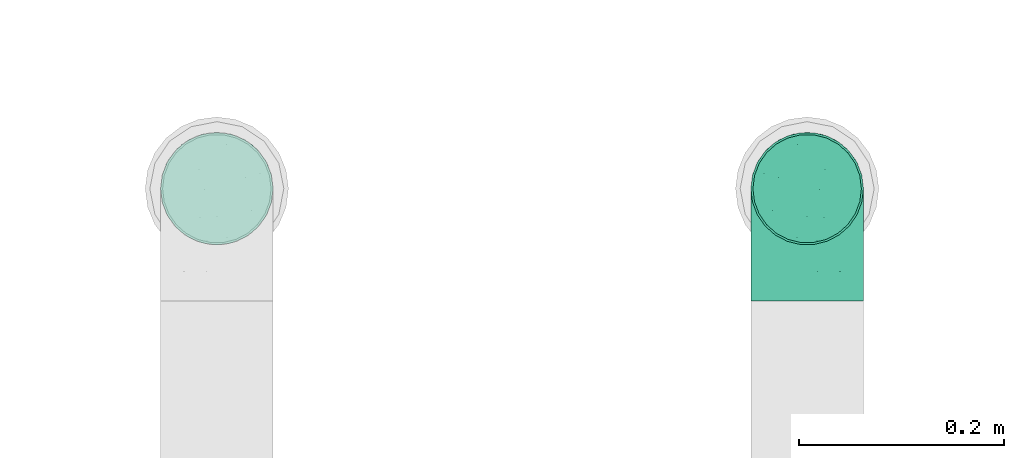
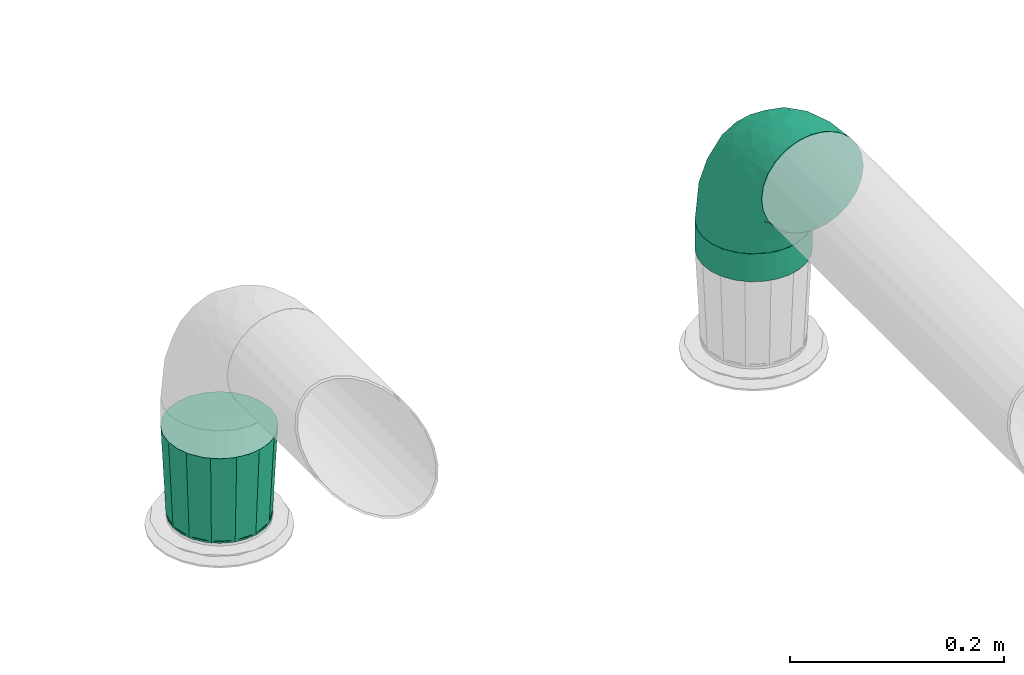
# One storey, part 65 of 103: 2 flow fittings, 1 flow segment.
"""IFC2X3 building model written with IfcOpenShell, lengths in millimetres."""

from ifc_helpers import new_model, entity, si_unit, converted_unit, derived_unit, direction, frame, origin_with_axes, origin_2d_with_axis, place, context, subcontext, project, spatial, hollow_circle, extrude, open_shell, surface_model, source, transform, mapped, material, layer, layer_set, layer_usage, type_object, element, save


model = new_model("IFC2X3")

# Units and contexts
model_context = context("Model", 3, precision=1e-05, world=origin_with_axes(), true_north=direction((0.0, 1.0)))
body_context = subcontext(model_context, "Body", "Model", "MODEL_VIEW")
ifc_project = project(units=[si_unit("AREAUNIT", "SQUARE_METRE"), si_unit("VOLUMEUNIT", "CUBIC_METRE", prefix="DECI"), si_unit("TIMEUNIT", "SECOND"), si_unit("THERMODYNAMICTEMPERATUREUNIT", "DEGREE_CELSIUS"), si_unit("PRESSUREUNIT", "PASCAL"), si_unit("MASSUNIT", "GRAM", prefix="KILO"), si_unit("LENGTHUNIT", "METRE", prefix="MILLI"), si_unit("POWERUNIT", "WATT"), si_unit("ELECTRICCURRENTUNIT", "AMPERE"), si_unit("ELECTRICVOLTAGEUNIT", "VOLT"), derived_unit("VOLUMETRICFLOWRATEUNIT", [(si_unit("VOLUMEUNIT", "CUBIC_METRE", prefix="DECI"), 1), (si_unit("TIMEUNIT", "SECOND"), -1)]), derived_unit("LINEARVELOCITYUNIT", [(si_unit("LENGTHUNIT", "METRE"), 1), (si_unit("TIMEUNIT", "SECOND"), -1)]), derived_unit("MASSDENSITYUNIT", [(si_unit("MASSUNIT", "GRAM", prefix="KILO"), 1), (si_unit("VOLUMEUNIT", "CUBIC_METRE"), -1)]), converted_unit("PLANEANGLEUNIT", "DEGREE", entity("IfcRatioMeasure", 0.01745), si_unit("PLANEANGLEUNIT", "RADIAN"), dimensions=[0, 0, 0, 0, 0, 0, 0])], contexts=[model_context])

# Site, building, storey
site_placement = place(None, origin_with_axes())
site = spatial("IfcSite", under=ifc_project, at=site_placement, CompositionType="ELEMENT")
building_placement = place(site_placement, origin_with_axes())
building = spatial("IfcBuilding", under=site, at=building_placement, Name="mc-building", CompositionType="ELEMENT")
storey_placement = place(building_placement, frame((0.0, 0.0, 5900.0), z_axis=(0.0, 0.0, 1.0), x_axis=(1.0, 0.0, 0.0)))
storey = spatial("IfcBuildingStorey", under=building, at=storey_placement, Name="3. Korrus", CompositionType="ELEMENT", Elevation=5900.0)

# Flow segment
ifc_material = material(Name="FZ1")
ifc_layer = layer(ifc_material, 0.0)
ifc_layer_set = layer_set([ifc_layer], Name="FZ1")
ifc_layer_usage = layer_usage(ifc_layer_set, "AXIS1", "POSITIVE", 0.0)
duct_segment_type = type_object("IfcDuctSegmentType", PredefinedType="RIGIDSEGMENT")
shared_shape_1 = source(origin_with_axes(), body_context, "Body", "SweptSolid", [
    extrude(hollow_circle(Radius=55.0, WallThickness=2.0, at=origin_2d_with_axis()), frame((0.0, 0.0, 0.0), z_axis=(1.0, 0.0, 0.0), x_axis=(0.0, 1.0, 0.0)), (0.0, 0.0, 1.0), 31.9),
])
flow_segment_placement = place(storey_placement, frame((26665.96154, 4730.85862, 2235.0), z_axis=(0.0, -1.0, 0.0), x_axis=(0.0, 0.0, -1.0)))
element("IfcFlowSegment", 1, at=flow_segment_placement, inside=storey, type_object=duct_segment_type, material=ifc_layer_usage, context=body_context, shape_type="MappedRepresentation", body=[
    mapped(shared_shape_1, transform((0.0, 0.0, 0.0), scale=1.0)),
])

# Flow fittings
duct_fitting_type_1 = type_object("IfcDuctFittingType", Name="BU", PredefinedType="BEND")
shared_shape_2 = source(origin_with_axes(), body_context, "Body", "SurfaceModel", [
    surface_model("IfcShellBasedSurfaceModel", [(-110.0, 0.0, -55.0), (-110.0, -14.23505, -53.12592), (-110.0, 14.23505, -53.12592), (-110.0, 53.12592, 14.23505), (-110.0, 27.5, -47.63139), (-110.0, 38.89087, -38.89087), (-110.0, -55.0, 0.0), (-110.0, -53.12592, 14.23505), (-110.0, -38.89087, -38.89087), (-110.0, -27.5, -47.63139), (-110.0, -53.12592, -14.23505), (-110.0, -47.63139, -27.5), (-110.0, -14.23505, 53.12592), (-110.0, 14.23505, 53.12592), (-110.0, 27.5, 47.63139), (-110.0, -47.63139, 27.5), (-110.0, -38.89087, 38.89087), (-110.0, -27.5, 47.63139), (-110.0, 0.0, 55.0), (-110.0, 55.0, 0.0), (-110.0, 53.12592, -14.23505), (-110.0, 47.63139, -27.5), (-110.0, 47.63139, 27.5), (-110.0, 38.89087, 38.89087), (-14.23505, 110.0, -53.12592), (-55.0, 110.0, 0.0), (0.0, 110.0, -55.0), (-27.5, 110.0, -47.63139), (-38.89087, 110.0, -38.89087), (-47.63139, 110.0, -27.5), (38.89087, 110.0, -38.89087), (53.12592, 110.0, 14.23505), (27.5, 110.0, -47.63139), (14.23505, 110.0, -53.12592), (47.63139, 110.0, -27.5), (53.12592, 110.0, -14.23505), (55.0, 110.0, 0.0), (-53.12592, 110.0, -14.23505), (-53.12592, 110.0, 14.23505), (-47.63139, 110.0, 27.5), (-38.89087, 110.0, 38.89087), (-27.5, 110.0, 47.63139), (0.0, 110.0, 55.0), (-14.23505, 110.0, 53.12592), (38.89087, 110.0, 38.89087), (47.63139, 110.0, 27.5), (27.5, 110.0, 47.63139), (14.23505, 110.0, 53.12592), (-64.21732, 48.68956, 43.63444), (-76.6405, 38.18013, 45.55988), (-60.44912, 32.56953, 51.94617), (-76.00813, 5.38378, 55.0), (-90.15553, 11.94394, 54.09138), (-78.5998, 26.77405, 50.81338), (-70.18771, 18.55163, 54.03432), (-75.55424, 54.2118, 32.41257), (-93.27622, 45.77614, 33.48188), (-96.12334, 22.13664, 50.81337), (-21.00813, 45.34362, 55.0), (-18.36258, 70.48427, 54.04484), (-32.04182, 59.64019, 52.24446), (-63.88653, 74.77858, 17.99134), (-74.66383, 63.08407, 19.92123), (-63.60674, 66.07878, 29.97482), (-99.597, 52.72185, 18.52927), (-93.11138, 56.59448, 10.50359), (-98.21577, 57.34403, 0.0), (-53.42855, 92.60092, 21.04759), (-88.54852, 54.8376, 21.04759), (-11.86161, 90.23965, 54.10313), (-5.38378, 76.00813, 55.0), (-57.34403, 98.21577, 0.0), (-56.64619, 93.12774, 10.22088), (-45.34362, 21.00813, 55.0), (-44.60838, 44.60838, 52.13415), (-92.68484, 35.46673, 43.63443), (-22.25266, 95.40765, 50.81337), (-35.97783, 90.61597, 43.63443), (-43.70931, 69.58671, 44.47149), (-27.23711, 77.39884, 50.81337), (-57.2828, 79.3123, 24.9774), (-58.67786, 84.31125, 16.04456), (-82.93277, 60.36161, 12.91784), (-49.88337, 54.51816, 47.224), (-74.57753, 66.83759, 9.55742), (-45.35812, 94.97281, 33.48188), (-59.18663, 88.95241, 0.0), (-51.517, 78.6292, 33.48188), (-65.14788, 80.03077, 0.0), (-56.45322, 62.06476, 39.63545), (-88.95241, 59.18663, 0.0), (-71.10913, 71.10913, 0.0), (-80.03077, 65.14788, 0.0), (-94.9309, 45.36788, -33.48188), (-93.11358, 56.60141, -10.46614), (-99.64997, 52.79499, -18.30015), (-90.20425, 36.08686, -43.63443), (-79.99933, 46.56772, -37.92748), (-76.00813, 5.38378, -55.0), (-72.75364, 19.68651, -53.60527), (-45.34362, 21.00813, -55.0), (-21.91957, 65.12078, -53.85897), (-5.38378, 76.00813, -55.0), (-21.00813, 45.34362, -55.0), (-35.41876, 92.89265, -43.63443), (-91.10309, 11.02766, -54.21832), (-45.77614, 93.27622, -33.48188), (-90.50474, 23.21022, -50.81337), (-70.92854, 33.31794, -49.51754), (-78.52933, 63.35627, -11.73997), (-24.91508, 84.05606, -50.81337), (-88.78941, 54.74452, -21.04759), (-69.59921, 57.34866, -33.48187), (-73.36422, 62.46673, -22.94182), (-63.49062, 67.59111, -28.46929), (-56.59448, 93.11138, -10.50359), (-54.8376, 88.54852, -21.04759), (-54.10679, 75.85581, -32.31867), (-57.75956, 31.09612, -52.80882), (-52.72185, 99.597, -18.52927), (-12.62913, 89.46304, -53.99097), (-34.46825, 66.46123, -50.04329), (-43.9837, 43.9837, -52.42279), (-65.78527, 72.58348, -17.68796), (-70.34468, 43.65295, -44.21951), (-57.47001, 51.99467, -44.91465), (-60.72547, 82.29174, -12.88567), (-42.34915, 74.24548, -43.63444), (-57.25194, 63.5016, -38.08211), (-80.95344, 53.56991, -29.32027), (-52.32891, 4.55257, -54.0482), (32.52942, 47.13398, -30.48571), (14.88266, 20.92917, -33.7947), (14.95561, 36.05775, -42.26543), (30.24048, 70.09027, -41.7461), (19.3559, 65.35825, -48.00507), (-70.35075, -46.44478, -19.5952), (-47.13398, -32.52942, -30.48571), (-28.49299, -30.5778, -16.4009), (-4.55257, 52.32891, -54.0482), (-22.4954, 22.4954, -53.25347), (-75.47368, -11.22546, -52.60718), (-81.32209, -51.5606, -9.98467), (-80.81763, -41.84862, -32.14655), (-70.09027, -30.24048, -41.7461), (-36.05774, -14.95561, -42.26543), (-9.15831, -10.852, -27.8997), (-65.35825, -19.3559, -48.00507), (11.22546, 75.47368, -52.60718), (3.94376, 43.9333, -50.53315), (-13.39742, 13.39743, -48.13058), (-43.9333, -3.94376, -50.53315), (49.37776, 67.29486, 0.0), (41.8609, 47.82256, -9.92641), (50.20582, 74.51695, -9.9731), (18.93131, 11.7156, -17.56239), (-27.5, -32.89419, 0.0), (-1.23348, -12.25375, -12.18106), (41.84862, 80.81763, -32.14655), (35.70604, 41.31408, -20.38235), (46.44478, 70.35075, -19.5952), (32.89419, 27.5, 0.0), (6.67262, -6.67262, 0.0), (-67.29486, -49.37776, 0.0), (-50.36265, -42.95545, -9.51562), (-5.47251, 5.47251, -39.92906), (-70.35075, -46.44478, 19.5952), (-74.51695, -50.20582, 9.9731), (-41.31407, -35.70604, 20.38235), (-47.13398, -32.52942, 30.48571), (-80.81763, -41.84862, 32.14655), (-4.55257, 52.32891, 54.0482), (11.22546, 75.47368, 52.60718), (-43.9333, -3.94376, 50.53315), (-65.35825, -19.3559, 48.00507), (-36.05774, -14.95561, 42.26543), (-70.09027, -30.24048, 41.7461), (-11.7156, -18.93131, 17.56239), (30.5778, 28.49299, 16.4009), (12.25375, 1.23348, 12.18106), (51.5606, 81.32209, 9.98467), (42.95545, 50.36265, 9.51562), (-75.47368, -11.22546, 52.60718), (-52.32891, 4.55257, 54.0482), (3.94376, 43.9333, 50.53315), (-22.4954, 22.4954, 53.25347), (-13.39742, 13.39743, 48.13058), (10.852, 9.15831, 27.8997), (-20.92916, -14.88266, 33.79469), (-47.82256, -41.8609, 9.92641), (32.52942, 47.13398, 30.48571), (46.44478, 70.35075, 19.5952), (41.84862, 80.81763, 32.14655), (30.24048, 70.09027, 41.7461), (19.3559, 65.35825, 48.00507), (14.95561, 36.05775, 42.26543), (-5.47251, 5.47251, 39.92906)], [open_shell([[[0, 1, 2]], [[2, 3, 4]], [[4, 3, 5]], [[2, 6, 7]], [[8, 6, 9]], [[1, 9, 6]], [[10, 6, 11]], [[8, 11, 6]], [[6, 2, 1]], [[12, 13, 14]], [[15, 2, 7]], [[16, 17, 2]], [[2, 17, 12]], [[12, 18, 13]], [[19, 20, 3]], [[5, 3, 21]], [[20, 21, 3]], [[22, 3, 2]], [[23, 22, 2]], [[12, 14, 2]], [[2, 14, 23]], [[15, 16, 2]], [[24, 25, 26]], [[27, 25, 24]], [[25, 28, 29]], [[28, 25, 27]], [[30, 26, 31]], [[26, 30, 32]], [[32, 33, 26]], [[34, 31, 35]], [[31, 34, 30]], [[35, 31, 36]], [[29, 37, 25]], [[38, 39, 26]], [[39, 40, 26]], [[41, 42, 40]], [[42, 26, 40]], [[42, 41, 43]], [[26, 44, 45]], [[31, 26, 45]], [[26, 46, 44]], [[47, 46, 26]], [[42, 47, 26]], [[25, 38, 26]], [[48, 49, 50]], [[18, 51, 52]], [[53, 54, 50]], [[55, 56, 49]], [[56, 22, 23]], [[13, 57, 14]], [[58, 59, 60]], [[61, 62, 63]], [[3, 64, 65]], [[53, 52, 54]], [[3, 65, 66]], [[67, 39, 38]], [[56, 68, 64]], [[65, 64, 68]], [[69, 59, 70]], [[38, 71, 72]], [[73, 58, 74]], [[75, 49, 56]], [[76, 69, 43]], [[53, 57, 52]], [[77, 78, 79]], [[41, 76, 43]], [[43, 69, 42]], [[55, 68, 56]], [[23, 14, 75]], [[76, 77, 79]], [[80, 67, 81]], [[62, 82, 68]], [[60, 78, 83]], [[62, 84, 82]], [[85, 77, 40]], [[81, 67, 72]], [[86, 72, 71]], [[87, 85, 67]], [[61, 81, 88]], [[77, 41, 40]], [[78, 77, 87]], [[23, 75, 56]], [[83, 89, 48]], [[85, 40, 39]], [[62, 68, 55]], [[89, 87, 63]], [[83, 48, 50]], [[57, 75, 14]], [[49, 75, 53]], [[67, 85, 39]], [[87, 77, 85]], [[63, 62, 55]], [[89, 55, 48]], [[80, 63, 87]], [[66, 65, 90]], [[66, 19, 3]], [[84, 91, 92]], [[92, 90, 82]], [[65, 82, 90]], [[61, 84, 62]], [[92, 82, 84]], [[68, 82, 65]], [[3, 22, 64]], [[56, 64, 22]], [[38, 25, 71]], [[81, 72, 86]], [[38, 72, 67]], [[91, 61, 88]], [[80, 81, 61]], [[63, 80, 61]], [[67, 80, 87]], [[77, 76, 41]], [[79, 59, 69]], [[79, 69, 76]], [[42, 69, 70]], [[60, 59, 79]], [[58, 70, 59]], [[78, 60, 79]], [[58, 60, 74]], [[52, 57, 13]], [[75, 57, 53]], [[18, 52, 13]], [[52, 51, 54]], [[51, 73, 54]], [[50, 73, 74]], [[73, 50, 54]], [[50, 74, 83]], [[60, 83, 74]], [[89, 83, 78]], [[87, 89, 78]], [[55, 89, 63]], [[50, 49, 53]], [[55, 49, 48]], [[81, 86, 88]], [[91, 84, 61]], [[5, 21, 93]], [[90, 94, 66]], [[20, 94, 95]], [[96, 93, 97]], [[98, 99, 100]], [[96, 4, 5]], [[101, 102, 103]], [[28, 27, 104]], [[2, 105, 0]], [[104, 106, 28]], [[99, 105, 107]], [[108, 107, 96]], [[90, 109, 94]], [[107, 2, 4]], [[20, 66, 94]], [[27, 24, 110]], [[109, 111, 94]], [[112, 113, 114]], [[37, 115, 71]], [[116, 106, 117]], [[99, 118, 100]], [[116, 115, 119]], [[37, 119, 115]], [[24, 120, 110]], [[121, 110, 101]], [[119, 106, 116]], [[101, 110, 120]], [[122, 103, 100]], [[117, 123, 116]], [[124, 125, 108]], [[115, 116, 126]], [[106, 29, 28]], [[26, 102, 120]], [[127, 104, 110]], [[97, 124, 96]], [[125, 122, 118]], [[128, 127, 125]], [[96, 5, 93]], [[115, 126, 86]], [[117, 106, 127]], [[111, 113, 129]], [[95, 93, 21]], [[97, 129, 112]], [[110, 104, 27]], [[106, 104, 127]], [[96, 107, 4]], [[99, 107, 108]], [[99, 108, 118]], [[105, 99, 98]], [[112, 114, 128]], [[121, 125, 127]], [[20, 19, 66]], [[109, 90, 92]], [[94, 111, 95]], [[91, 123, 109]], [[129, 113, 112]], [[93, 95, 111]], [[21, 20, 95]], [[71, 115, 86]], [[71, 25, 37]], [[123, 91, 88]], [[126, 116, 123]], [[123, 88, 126]], [[86, 126, 88]], [[37, 29, 119]], [[106, 119, 29]], [[129, 93, 111]], [[124, 112, 125]], [[0, 105, 98]], [[107, 105, 2]], [[125, 118, 108]], [[100, 118, 122]], [[93, 129, 97]], [[113, 111, 109]], [[109, 123, 113]], [[114, 123, 117]], [[123, 114, 113]], [[128, 114, 117]], [[127, 128, 117]], [[112, 128, 125]], [[103, 122, 101]], [[110, 121, 127]], [[101, 122, 121]], [[125, 121, 122]], [[26, 120, 24]], [[101, 120, 102]], [[96, 124, 108]], [[92, 91, 109]], [[112, 124, 97]], [[100, 130, 98]], [[131, 132, 133]], [[32, 134, 135]], [[136, 137, 138]], [[139, 140, 103]], [[98, 141, 0]], [[142, 10, 136]], [[143, 144, 137]], [[6, 10, 142]], [[137, 145, 146]], [[144, 147, 145]], [[143, 136, 11]], [[11, 136, 10]], [[8, 143, 11]], [[148, 149, 139]], [[8, 9, 144]], [[9, 1, 147]], [[130, 141, 98]], [[103, 140, 100]], [[148, 135, 149]], [[150, 151, 140]], [[152, 153, 154]], [[130, 140, 151]], [[148, 26, 33]], [[147, 1, 141]], [[155, 146, 132]], [[156, 138, 157]], [[134, 30, 158]], [[150, 140, 149]], [[158, 30, 34]], [[30, 134, 32]], [[153, 159, 160]], [[131, 160, 159]], [[144, 145, 137]], [[36, 152, 154]], [[146, 138, 137]], [[155, 161, 162]], [[158, 160, 131]], [[133, 149, 135]], [[156, 163, 164]], [[163, 142, 164]], [[139, 103, 102]], [[153, 152, 161]], [[34, 35, 160]], [[162, 157, 155]], [[132, 165, 133]], [[157, 146, 155]], [[140, 130, 100]], [[141, 130, 151]], [[141, 151, 147]], [[141, 1, 0]], [[102, 26, 148]], [[140, 139, 149]], [[102, 148, 139]], [[135, 33, 32]], [[151, 150, 145]], [[9, 147, 144]], [[151, 145, 147]], [[145, 165, 146]], [[135, 148, 33]], [[133, 135, 134]], [[131, 133, 134]], [[133, 165, 150]], [[133, 150, 149]], [[145, 150, 165]], [[132, 131, 159]], [[146, 165, 132]], [[160, 158, 34]], [[134, 158, 131]], [[144, 143, 8]], [[136, 143, 137]], [[155, 153, 161]], [[154, 153, 160]], [[153, 155, 159]], [[132, 159, 155]], [[160, 35, 154]], [[36, 154, 35]], [[164, 136, 138]], [[6, 142, 163]], [[136, 164, 142]], [[156, 164, 138]], [[156, 157, 162]], [[146, 157, 138]], [[15, 7, 166]], [[6, 163, 167]], [[168, 169, 166]], [[166, 169, 170]], [[171, 172, 70]], [[173, 174, 175]], [[17, 176, 174]], [[177, 156, 162]], [[176, 16, 170]], [[170, 16, 15]], [[161, 178, 179]], [[152, 180, 181]], [[182, 173, 183]], [[18, 12, 182]], [[184, 185, 186]], [[183, 185, 73]], [[183, 73, 51]], [[177, 187, 188]], [[189, 168, 166]], [[187, 178, 190]], [[16, 176, 17]], [[161, 152, 181]], [[45, 191, 31]], [[45, 44, 192]], [[192, 191, 45]], [[180, 36, 31]], [[193, 194, 195]], [[46, 47, 194]], [[193, 195, 190]], [[193, 44, 46]], [[172, 42, 70]], [[185, 58, 73]], [[189, 163, 156]], [[163, 189, 167]], [[70, 58, 171]], [[184, 171, 185]], [[169, 188, 175]], [[180, 31, 191]], [[192, 193, 190]], [[191, 190, 178]], [[182, 174, 173]], [[194, 47, 172]], [[190, 195, 187]], [[186, 185, 173]], [[162, 179, 177]], [[188, 196, 175]], [[179, 187, 177]], [[185, 171, 58]], [[172, 171, 184]], [[172, 184, 194]], [[172, 47, 42]], [[51, 18, 182]], [[185, 183, 173]], [[51, 182, 183]], [[174, 12, 17]], [[184, 186, 195]], [[46, 194, 193]], [[184, 195, 194]], [[195, 196, 187]], [[174, 182, 12]], [[175, 174, 176]], [[169, 175, 176]], [[175, 196, 186]], [[175, 186, 173]], [[195, 186, 196]], [[188, 169, 168]], [[187, 196, 188]], [[166, 170, 15]], [[176, 170, 169]], [[193, 192, 44]], [[191, 192, 190]], [[177, 189, 156]], [[167, 189, 166]], [[189, 177, 168]], [[188, 168, 177]], [[166, 7, 167]], [[6, 167, 7]], [[181, 191, 178]], [[36, 180, 152]], [[191, 181, 180]], [[161, 181, 178]], [[161, 179, 162]], [[187, 179, 178]]])]),
])
flow_fitting_1_placement = place(storey_placement, frame((26665.96154, 4730.85862, 2345.0), z_axis=(-1.0, 0.0, 0.0), x_axis=(0.0, 1.0, 0.0)))
element("IfcFlowFitting", 2, at=flow_fitting_1_placement, inside=storey, type_object=duct_fitting_type_1, Name="BU", context=body_context, shape_type="MappedRepresentation", body=[
    mapped(shared_shape_2, transform((0.0, 0.0, 0.0), scale=1.0)),
])
duct_fitting_type_2 = type_object("IfcDuctFittingType", PredefinedType="TRANSITION")
shared_shape_3 = source(origin_with_axes(), body_context, "Body", "SurfaceModel", [
    surface_model("IfcShellBasedSurfaceModel", [(100.0, -55.0, 0.0), (100.0, -12.23865, 53.62104), (100.0, -34.29194, 43.00073), (100.0, 49.55329, 23.86361), (100.0, 34.29194, 43.00073), (100.0, 49.55329, -23.86361), (0.0, -45.04844, -21.69419), (0.0, -50.0, 0.0), (0.0, -45.04844, 21.69419), (0.0, 31.17449, 39.09157), (0.0, 45.04844, 21.69419), (0.0, 50.0, 0.0), (98.0, 47.63139, 27.5), (98.0, 0.0, 55.0), (98.0, 38.89087, 38.89087), (98.0, -38.89087, 38.89087), (98.0, -47.63139, 27.5), (100.0, 12.23865, 53.62104), (100.0, -49.55329, 23.86361), (100.0, 55.0, 0.0), (100.0, 12.23865, -53.62104), (100.0, 34.29194, -43.00073), (100.0, -49.55329, -23.86361), (100.0, -34.29194, -43.00073), (100.0, -12.23865, -53.62104), (0.0, -31.17449, 39.09157), (0.0, -11.12605, 48.7464), (0.0, 11.12605, 48.7464), (0.0, -31.17449, -39.09157), (0.0, 11.12605, -48.7464), (0.0, -11.12605, -48.7464), (0.0, 45.04844, -21.69419), (0.0, 31.17449, -39.09157), (0.0, 47.52422, -10.84709), (0.0, 38.11147, -30.39288), (100.0, 41.92261, -33.43217), (100.0, -41.92261, -33.43217), (0.0, -38.11147, -30.39288), (100.0, 23.2653, -48.31088), (0.0, 21.15027, -43.91899), (100.0, 52.32388, -11.72483), (0.0, 0.0, -48.7464), (100.0, 0.0, -53.62104), (0.0, -21.15027, -43.91899), (100.0, -23.2653, -48.31088), (0.0, -47.52422, -10.84709), (100.0, -52.32388, -11.72483), (0.0, -47.52422, 10.84709), (0.0, -38.11147, 30.39288), (100.0, -41.92261, 33.43217), (100.0, 41.92261, 33.43217), (0.0, 38.11147, 30.39288), (100.0, -23.2653, 48.31088), (0.0, -21.15027, 43.91899), (100.0, -52.32388, 11.72483), (0.0, 0.0, 48.7464), (100.0, 0.0, 53.62104), (0.0, 21.15027, 43.91899), (100.0, 23.2653, 48.31088), (0.0, 47.52422, 10.84709), (100.0, 52.32388, 11.72483), (100.0, -14.23505, -53.12592), (100.0, 0.0, -55.0), (100.0, -27.5, -47.63139), (100.0, 27.5, -47.63139), (100.0, -38.89087, -38.89087), (100.0, -53.12592, -14.23505), (100.0, -47.63139, -27.5), (100.0, -47.63139, 27.5), (100.0, 14.23505, -53.12592), (100.0, 38.89087, -38.89087), (100.0, 47.63139, -27.5), (100.0, 47.63139, 27.5), (100.0, 53.12592, -14.23505), (100.0, -53.12592, 14.23505), (100.0, -38.89087, 38.89087), (100.0, -27.5, 47.63139), (100.0, 0.0, 55.0), (100.0, -14.23505, 53.12592), (100.0, 53.12592, 14.23505), (100.0, 38.89087, 38.89087), (100.0, 27.5, 47.63139), (100.0, 14.23505, 53.12592), (98.0, -27.5, 47.63139), (98.0, -14.23505, 53.12592), (98.0, -53.12592, -14.23505), (98.0, 14.23505, 53.12592), (98.0, 27.5, 47.63139), (98.0, 53.12592, 14.23505), (98.0, 55.0, 0.0), (98.0, -47.63139, -27.5), (98.0, -53.12592, 14.23505), (98.0, 27.5, -47.63139), (98.0, -27.5, -47.63139), (98.0, -38.89087, -38.89087), (98.0, 0.0, -55.0), (98.0, -14.23505, -53.12592), (98.0, 38.89087, -38.89087), (98.0, 47.63139, -27.5), (98.0, 53.12592, -14.23505), (98.0, 14.23505, -53.12592), (98.0, -55.0, 0.0), (0.0, 0.0, 50.0), (0.0, 35.35534, 35.35534), (0.0, -12.94095, 48.29629), (0.0, -25.0, 43.30127), (0.0, -35.35534, 35.35534), (0.0, -48.29629, 12.94095), (0.0, -43.30127, 25.0), (0.0, 25.0, 43.30127), (0.0, 12.94095, 48.29629), (0.0, 43.30127, 25.0), (0.0, 48.29629, 12.94095), (0.0, 25.0, -43.30127), (0.0, 48.29629, -12.94095), (0.0, -48.29629, -12.94095), (0.0, -43.30127, -25.0), (0.0, -12.94095, -48.29629), (0.0, -25.0, -43.30127), (0.0, -35.35534, -35.35534), (0.0, 43.30127, -25.0), (0.0, 35.35534, -35.35534), (0.0, 12.94095, -48.29629), (0.0, 0.0, -50.0), (2.0, -35.35534, -35.35534), (2.0, -25.0, -43.30127), (2.0, -12.94095, -48.29629), (2.0, -43.30127, -25.0), (2.0, 0.0, -50.0), (2.0, -48.29629, -12.94095), (2.0, -50.0, 0.0), (2.0, 12.94095, -48.29629), (2.0, 25.0, -43.30127), (2.0, 43.30127, -25.0), (2.0, 48.29629, -12.94095), (2.0, 35.35534, -35.35534), (2.0, -48.29629, 12.94095), (2.0, -35.35534, 35.35534), (2.0, -43.30127, 25.0), (2.0, 35.35534, 35.35534), (2.0, -12.94095, 48.29629), (2.0, -25.0, 43.30127), (2.0, 0.0, 50.0), (2.0, 43.30127, 25.0), (2.0, 48.29629, 12.94095), (2.0, 50.0, 0.0), (2.0, 25.0, 43.30127), (2.0, 12.94095, 48.29629)], [open_shell([[[0, 1, 2]], [[3, 4, 5]], [[6, 7, 8]], [[9, 10, 11]], [[12, 13, 14]], [[15, 13, 16]], [[0, 4, 17]], [[2, 18, 0]], [[1, 0, 17]], [[3, 5, 19]], [[20, 21, 5]], [[22, 20, 5]], [[22, 5, 0]], [[22, 23, 24]], [[22, 24, 20]], [[4, 0, 5]], [[8, 25, 6]], [[6, 25, 26]], [[6, 26, 27]], [[11, 27, 9]], [[28, 6, 29]], [[30, 28, 29]], [[31, 6, 11]], [[31, 32, 29]], [[31, 29, 6]], [[27, 11, 6]], [[31, 33, 5]], [[34, 35, 32]], [[36, 22, 6]], [[36, 37, 23]], [[38, 29, 39]], [[33, 40, 5]], [[33, 11, 40]], [[19, 40, 11]], [[32, 21, 39]], [[32, 35, 21]], [[34, 31, 35]], [[30, 41, 42]], [[28, 43, 44]], [[42, 41, 20]], [[7, 45, 46]], [[38, 39, 21]], [[46, 0, 7]], [[6, 37, 36]], [[38, 20, 29]], [[43, 30, 24]], [[42, 24, 30]], [[28, 23, 37]], [[6, 22, 45]], [[35, 31, 5]], [[44, 43, 24]], [[20, 41, 29]], [[46, 45, 22]], [[44, 23, 28]], [[8, 47, 18]], [[48, 49, 25]], [[50, 3, 10]], [[50, 51, 4]], [[52, 26, 53]], [[47, 54, 18]], [[47, 7, 54]], [[0, 54, 7]], [[25, 2, 53]], [[25, 49, 2]], [[48, 8, 49]], [[27, 55, 56]], [[9, 57, 58]], [[56, 55, 1]], [[11, 59, 60]], [[52, 53, 2]], [[60, 19, 11]], [[10, 51, 50]], [[52, 1, 26]], [[57, 27, 17]], [[56, 17, 27]], [[9, 4, 51]], [[10, 3, 59]], [[49, 8, 18]], [[58, 57, 17]], [[1, 55, 26]], [[60, 59, 3]], [[58, 4, 9]], [[61, 62, 63]], [[63, 64, 65]], [[66, 67, 68]], [[65, 64, 67]], [[67, 64, 68]], [[69, 64, 62]], [[64, 63, 62]], [[70, 71, 64]], [[72, 64, 71]], [[71, 73, 19]], [[74, 0, 66]], [[72, 68, 64]], [[75, 68, 76]], [[77, 78, 76]], [[72, 76, 68]], [[76, 72, 77]], [[79, 72, 19]], [[19, 72, 71]], [[80, 81, 77]], [[77, 72, 80]], [[82, 77, 81]], [[74, 66, 68]], [[83, 84, 13]], [[15, 83, 13]], [[12, 16, 13]], [[16, 12, 85]], [[86, 87, 13]], [[87, 14, 13]], [[88, 89, 12]], [[89, 90, 12]], [[91, 16, 85]], [[90, 85, 12]], [[89, 92, 90]], [[93, 94, 95]], [[95, 94, 90]], [[96, 93, 95]], [[97, 92, 98]], [[98, 89, 99]], [[100, 95, 92]], [[92, 89, 98]], [[90, 92, 95]], [[101, 91, 85]], [[89, 73, 99]], [[99, 71, 98]], [[92, 97, 64]], [[70, 97, 98]], [[100, 92, 69]], [[73, 71, 99]], [[89, 19, 73]], [[92, 64, 69]], [[64, 97, 70]], [[98, 71, 70]], [[100, 69, 62]], [[62, 95, 100]], [[95, 61, 96]], [[96, 63, 93]], [[90, 94, 67]], [[65, 94, 93]], [[85, 90, 66]], [[63, 65, 93]], [[96, 61, 63]], [[85, 66, 0]], [[66, 90, 67]], [[94, 65, 67]], [[85, 0, 101]], [[62, 61, 95]], [[101, 74, 91]], [[91, 68, 16]], [[83, 15, 76]], [[75, 15, 16]], [[84, 83, 78]], [[74, 68, 91]], [[101, 0, 74]], [[83, 76, 78]], [[76, 15, 75]], [[16, 68, 75]], [[84, 78, 77]], [[77, 13, 84]], [[13, 82, 86]], [[86, 81, 87]], [[12, 14, 72]], [[80, 14, 87]], [[88, 12, 79]], [[81, 80, 87]], [[86, 82, 81]], [[88, 79, 19]], [[79, 12, 72]], [[14, 80, 72]], [[88, 19, 89]], [[77, 82, 13]], [[102, 103, 104]], [[105, 104, 106]], [[107, 108, 106]], [[103, 106, 104]], [[106, 103, 107]], [[109, 103, 110]], [[103, 102, 110]], [[111, 112, 103]], [[113, 103, 112]], [[112, 11, 114]], [[107, 103, 113]], [[113, 115, 107]], [[116, 115, 117]], [[117, 118, 119]], [[116, 117, 119]], [[117, 115, 113]], [[120, 121, 114]], [[113, 114, 121]], [[113, 122, 117]], [[113, 112, 114]], [[117, 122, 123]], [[7, 107, 115]], [[124, 125, 126]], [[127, 124, 126]], [[128, 129, 126]], [[127, 126, 129]], [[130, 129, 128]], [[131, 132, 128]], [[132, 130, 128]], [[133, 134, 135]], [[132, 135, 134]], [[132, 134, 130]], [[134, 136, 130]], [[137, 138, 136]], [[137, 136, 139]], [[140, 137, 139]], [[141, 137, 140]], [[142, 140, 139]], [[143, 139, 144]], [[144, 134, 145]], [[146, 147, 139]], [[139, 136, 144]], [[139, 147, 142]], [[136, 134, 144]], [[11, 134, 114]], [[114, 133, 120]], [[113, 121, 132]], [[135, 121, 120]], [[122, 113, 131]], [[134, 133, 114]], [[11, 145, 134]], [[113, 132, 131]], [[132, 121, 135]], [[120, 133, 135]], [[122, 131, 128]], [[128, 123, 122]], [[123, 126, 117]], [[117, 125, 118]], [[116, 119, 127]], [[124, 119, 118]], [[115, 116, 129]], [[125, 124, 118]], [[117, 126, 125]], [[115, 129, 130]], [[129, 116, 127]], [[119, 124, 127]], [[115, 130, 7]], [[128, 126, 123]], [[7, 136, 107]], [[107, 138, 108]], [[105, 106, 141]], [[137, 106, 108]], [[104, 105, 140]], [[136, 138, 107]], [[7, 130, 136]], [[105, 141, 140]], [[141, 106, 137]], [[108, 138, 137]], [[104, 140, 142]], [[142, 102, 104]], [[102, 147, 110]], [[110, 146, 109]], [[111, 103, 143]], [[139, 103, 109]], [[112, 111, 144]], [[146, 139, 109]], [[110, 147, 146]], [[112, 144, 145]], [[144, 111, 143]], [[103, 139, 143]], [[112, 145, 11]], [[142, 147, 102]]])]),
])
flow_fitting_2_placement = place(storey_placement, frame((26088.96136, 4730.85862, 2103.1), z_axis=(0.0, -1.0, 0.0), x_axis=(0.0, 0.0, 1.0)))
element("IfcFlowFitting", 3, at=flow_fitting_2_placement, inside=storey, type_object=duct_fitting_type_2, context=body_context, shape_type="MappedRepresentation", body=[
    mapped(shared_shape_3, transform((0.0, 0.0, 0.0), scale=1.0)),
])

save(model, "model.ifc")
